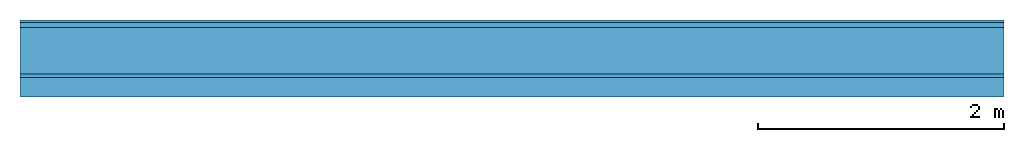
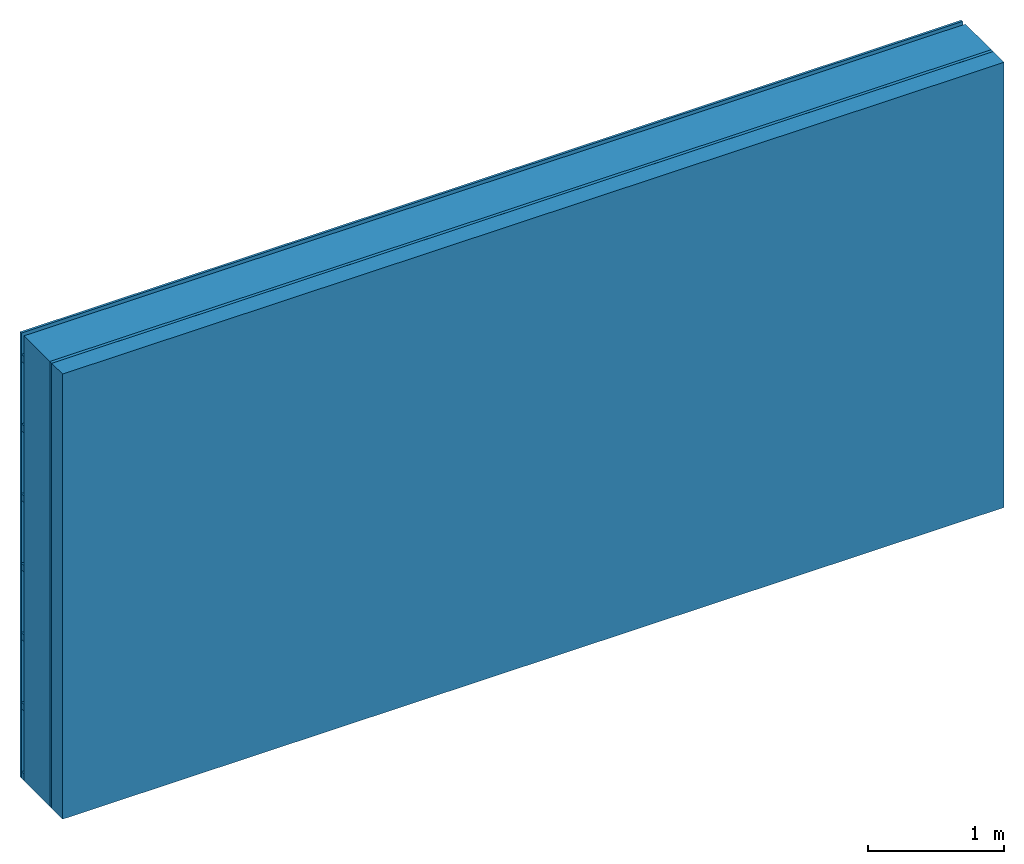
# One storey: 3 plates, 2 members, 1 element without a shape of its own.
"""IFC4 building model written with IfcOpenShell, lengths in metres."""

from ifc_helpers import new_model, si_unit, derived_unit, direction, frame, frame_2d, origin, origin_with_axes, place, context, project, spatial, rectangle, extrude, material, layer, layer_set, type_object, element, aggregate, save


model = new_model("IFC4")

# Units and contexts
plan_context = context("Plan", 3, precision=1e-05, world=origin(), true_north=direction((0.0, 1.0)))
model_context = context("Model", 3, precision=1e-05, world=origin(), true_north=direction((0.0, 1.0)))
ifc_project = project(units=[si_unit("LENGTHUNIT", "METRE"), derived_unit("SOUNDPRESSUREUNIT", [(si_unit("PRESSUREUNIT", "PASCAL", prefix="MICRO"), 0)]), si_unit("ENERGYUNIT", "JOULE", prefix="MEGA"), si_unit("MASSUNIT", "GRAM", prefix="KILO"), derived_unit("THERMALTRANSMITTANCEUNIT", [(si_unit("POWERUNIT", "WATT"), 1), (si_unit("AREAUNIT", "SQUARE_METRE"), -1), (si_unit("THERMODYNAMICTEMPERATUREUNIT", "KELVIN"), -1)]), derived_unit("AREADENSITYUNIT", [(si_unit("MASSUNIT", "GRAM", prefix="KILO"), 1), (si_unit("AREAUNIT", "SQUARE_METRE"), -1)]), derived_unit("USERDEFINED", [(si_unit("ENERGYUNIT", "JOULE", prefix="MEGA"), 1), (si_unit("AREAUNIT", "SQUARE_METRE"), -1)])], contexts=[plan_context, model_context])

# Site, building, storey
site = spatial("IfcSite", under=ifc_project)
building_placement = place(None, origin())
building = spatial("IfcBuilding", under=site, at=building_placement)
storey_placement = place(building_placement, origin())
storey = spatial("IfcBuildingStorey", under=building, at=storey_placement)

# Wall, members, plates
ifc_material_1 = material(Name="Wood cladding horizontal, closed")
ifc_layer_1 = layer(ifc_material_1, 0.02, Name="Cover 1st layer")
ifc_layer_2 = layer(None, 0.04, Name="Battens / profiles (ventilation)")
ifc_material_2 = material(Category="10.009")
ifc_layer_3 = layer(ifc_material_2, 0.38, Name="outside 2nd layer")
ifc_material_3 = material(Category="07.009")
ifc_layer_4 = layer(ifc_material_3, 0.027, Name="outside 1st layer")
ifc_material_4 = material(Name="Rigid, of the art")
ifc_layer_5 = layer(ifc_material_4, 0.0, Name="Bond")
ifc_layer_6 = layer(None, 0.16, Name="Support")
ifc_material_5 = material(Name="of the art")
ifc_layer_7 = layer(ifc_material_5, 0.0, Name="Bond")
ifc_layer_set = layer_set([ifc_layer_1, ifc_layer_2, ifc_layer_3, ifc_layer_4, ifc_layer_5, ifc_layer_6, ifc_layer_7])
wall_type = type_object("IfcWallType", Name="D1196", PredefinedType="NOTDEFINED", material=ifc_layer_set)
wall_placement = place(None, frame((0.0, 0.0, 0.0), z_axis=(0.0, -1.0, 0.0), x_axis=(1.0, 0.0, 0.0)))
wall = element("IfcWall", 1, at=wall_placement, inside=storey, type_object=wall_type, material=ifc_layer_set, Name="Wall #1")
ifc_material_6 = material()
member_1_placement = place(wall_placement, origin())
member_1 = element("IfcMember", 2, at=member_1_placement, material=ifc_material_6, Name="Battens / profiles (ventilation)", context=plan_context, shape_type="SweptSolid", body=[
    extrude(rectangle(XDim=0.06, YDim=0.04, at=frame_2d((0.03, 0.02), x_axis=(1.0, 0.0))), frame((0.0, 0.0, 0.02), z_axis=(1.0, 0.0, 0.0), x_axis=(0.0, 1.0, 0.0)), (0.0, 0.0, 1.0), 8.0),
    extrude(rectangle(XDim=0.06, YDim=0.04, at=frame_2d((0.03, 0.02), x_axis=(1.0, 0.0))), frame((0.0, 0.625, 0.02), z_axis=(1.0, 0.0, 0.0), x_axis=(0.0, 1.0, 0.0)), (0.0, 0.0, 1.0), 8.0),
    extrude(rectangle(XDim=0.06, YDim=0.04, at=frame_2d((0.03, 0.02), x_axis=(1.0, 0.0))), frame((0.0, 1.25, 0.02), z_axis=(1.0, 0.0, 0.0), x_axis=(0.0, 1.0, 0.0)), (0.0, 0.0, 1.0), 8.0),
    extrude(rectangle(XDim=0.06, YDim=0.04, at=frame_2d((0.03, 0.02), x_axis=(1.0, 0.0))), frame((0.0, 1.875, 0.02), z_axis=(1.0, 0.0, 0.0), x_axis=(0.0, 1.0, 0.0)), (0.0, 0.0, 1.0), 8.0),
    extrude(rectangle(XDim=0.06, YDim=0.04, at=frame_2d((0.03, 0.02), x_axis=(1.0, 0.0))), frame((0.0, 2.5, 0.02), z_axis=(1.0, 0.0, 0.0), x_axis=(0.0, 1.0, 0.0)), (0.0, 0.0, 1.0), 8.0),
    extrude(rectangle(XDim=0.06, YDim=0.04, at=frame_2d((0.03, 0.02), x_axis=(1.0, 0.0))), frame((0.0, 3.125, 0.02), z_axis=(1.0, 0.0, 0.0), x_axis=(0.0, 1.0, 0.0)), (0.0, 0.0, 1.0), 8.0),
    extrude(rectangle(XDim=0.06, YDim=0.04, at=frame_2d((0.03, 0.02), x_axis=(1.0, 0.0))), frame((0.0, 3.75, 0.02), z_axis=(1.0, 0.0, 0.0), x_axis=(0.0, 1.0, 0.0)), (0.0, 0.0, 1.0), 8.0),
])
ifc_material_7 = material(Name="Solid timber panel")
member_2_placement = place(wall_placement, origin())
member_2 = element("IfcMember", 3, at=member_2_placement, material=ifc_material_7, Name="Support", context=plan_context, shape_type="SweptSolid", body=[
    extrude(rectangle(XDim=1.0, YDim=0.16, at=frame_2d((0.5, 0.08), x_axis=(1.0, 0.0))), frame((0.0, 4.0, 0.467), z_axis=(0.0, -1.0, 0.0), x_axis=(1.0, 0.0, 0.0)), (0.0, 0.0, 1.0), 4.0),
    extrude(rectangle(XDim=1.0, YDim=0.16, at=frame_2d((0.5, 0.08), x_axis=(1.0, 0.0))), frame((1.0, 4.0, 0.467), z_axis=(0.0, -1.0, 0.0), x_axis=(1.0, 0.0, 0.0)), (0.0, 0.0, 1.0), 4.0),
    extrude(rectangle(XDim=1.0, YDim=0.16, at=frame_2d((0.5, 0.08), x_axis=(1.0, 0.0))), frame((2.0, 4.0, 0.467), z_axis=(0.0, -1.0, 0.0), x_axis=(1.0, 0.0, 0.0)), (0.0, 0.0, 1.0), 4.0),
    extrude(rectangle(XDim=1.0, YDim=0.16, at=frame_2d((0.5, 0.08), x_axis=(1.0, 0.0))), frame((3.0, 4.0, 0.467), z_axis=(0.0, -1.0, 0.0), x_axis=(1.0, 0.0, 0.0)), (0.0, 0.0, 1.0), 4.0),
    extrude(rectangle(XDim=1.0, YDim=0.16, at=frame_2d((0.5, 0.08), x_axis=(1.0, 0.0))), frame((4.0, 4.0, 0.467), z_axis=(0.0, -1.0, 0.0), x_axis=(1.0, 0.0, 0.0)), (0.0, 0.0, 1.0), 4.0),
    extrude(rectangle(XDim=1.0, YDim=0.16, at=frame_2d((0.5, 0.08), x_axis=(1.0, 0.0))), frame((5.0, 4.0, 0.467), z_axis=(0.0, -1.0, 0.0), x_axis=(1.0, 0.0, 0.0)), (0.0, 0.0, 1.0), 4.0),
    extrude(rectangle(XDim=1.0, YDim=0.16, at=frame_2d((0.5, 0.08), x_axis=(1.0, 0.0))), frame((6.0, 4.0, 0.467), z_axis=(0.0, -1.0, 0.0), x_axis=(1.0, 0.0, 0.0)), (0.0, 0.0, 1.0), 4.0),
    extrude(rectangle(XDim=1.0, YDim=0.16, at=frame_2d((0.5, 0.08), x_axis=(1.0, 0.0))), frame((7.0, 4.0, 0.467), z_axis=(0.0, -1.0, 0.0), x_axis=(1.0, 0.0, 0.0)), (0.0, 0.0, 1.0), 4.0),
])
plate_1_placement = place(wall_placement, origin())
plate_1 = element("IfcPlate", 4, at=plate_1_placement, material=ifc_material_1, Name="Cover 1st layer", context=plan_context, shape_type="SweptSolid", body=[
    extrude(rectangle(XDim=8.0, YDim=4.0, at=frame_2d((4.0, 2.0), x_axis=(1.0, 0.0))), origin_with_axes(), (0.0, 0.0, 1.0), 0.02),
])
plate_2_placement = place(wall_placement, origin())
plate_2 = element("IfcPlate", 5, at=plate_2_placement, material=ifc_material_2, Name="outside 2nd layer", context=plan_context, shape_type="SweptSolid", body=[
    extrude(rectangle(XDim=8.0, YDim=4.0, at=frame_2d((4.0, 2.0), x_axis=(1.0, 0.0))), frame((0.0, 0.0, 0.06), z_axis=(0.0, 0.0, 1.0), x_axis=(1.0, 0.0, 0.0)), (0.0, 0.0, 1.0), 0.38),
])
plate_3_placement = place(wall_placement, origin())
plate_3 = element("IfcPlate", 6, at=plate_3_placement, material=ifc_material_3, Name="outside 1st layer", context=plan_context, shape_type="SweptSolid", body=[
    extrude(rectangle(XDim=8.0, YDim=4.0, at=frame_2d((4.0, 2.0), x_axis=(1.0, 0.0))), frame((0.0, 0.0, 0.44), z_axis=(0.0, 0.0, 1.0), x_axis=(1.0, 0.0, 0.0)), (0.0, 0.0, 1.0), 0.027),
])
aggregate(wall, [plate_1, member_1, plate_2, plate_3, member_2])

save(model, "model.ifc")
